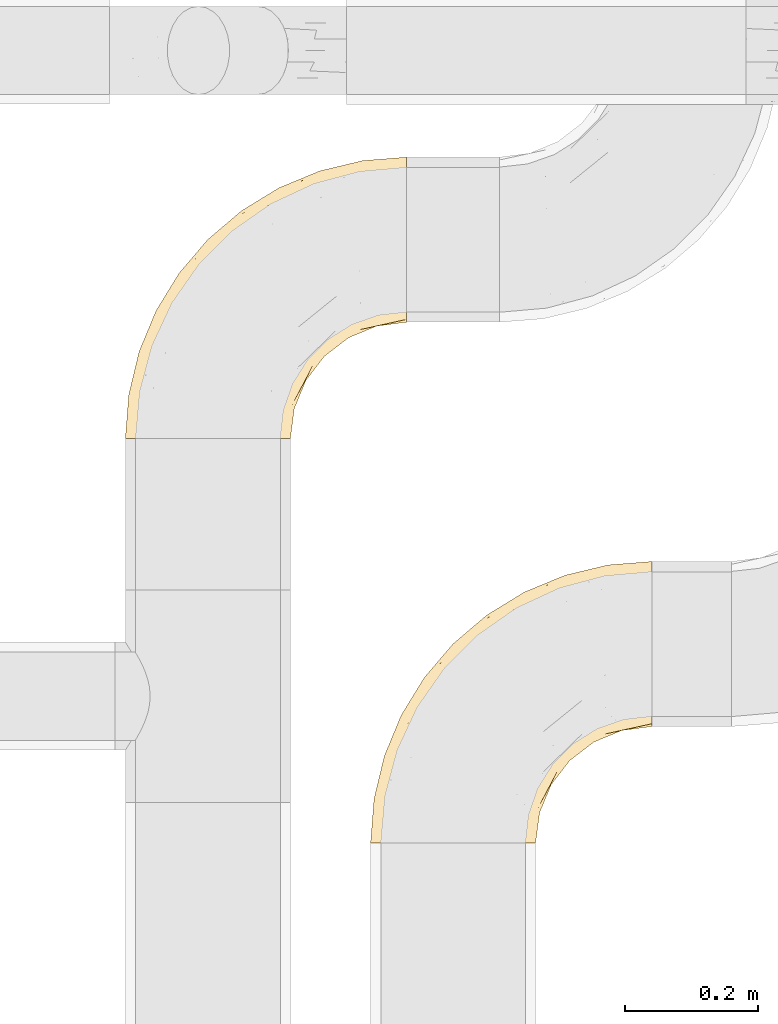
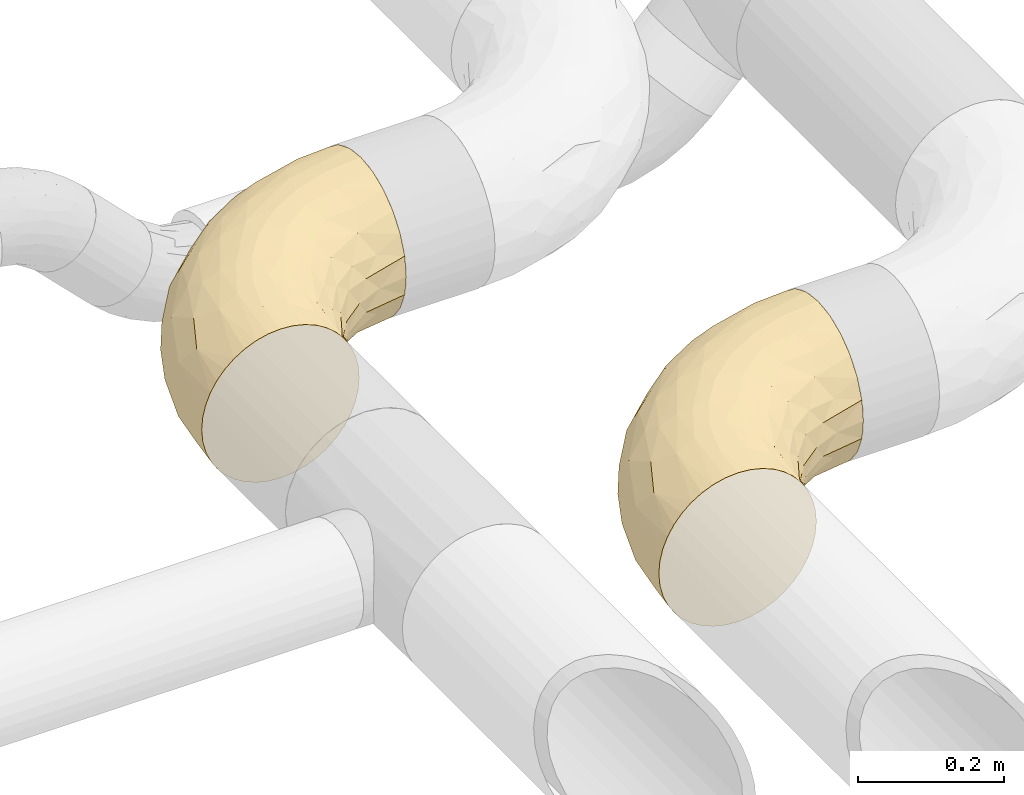
# One storey, part 38 of 93: 2 coverings.
"""IFC2X3 building model written with IfcOpenShell, lengths in millimetres."""

from ifc_helpers import new_model, entity, si_unit, converted_unit, derived_unit, direction, frame, origin, place, context, subcontext, project, spatial, faceted_brep, element, save


model = new_model("IFC2X3")

# Units and contexts
model_context = context("Model", 3, precision=0.01, world=origin(), true_north=direction((6.12303176911189e-17, 1.0)))
body_context = subcontext(model_context, "Body", "Model", "MODEL_VIEW")
ifc_project = project(units=[si_unit("LENGTHUNIT", "METRE", prefix="MILLI"), si_unit("AREAUNIT", "SQUARE_METRE"), si_unit("VOLUMEUNIT", "CUBIC_METRE"), converted_unit("PLANEANGLEUNIT", "DEGREE", entity("IfcRatioMeasure", 0.0174532925199433), si_unit("PLANEANGLEUNIT", "RADIAN"), dimensions=[0, 0, 0, 0, 0, 0, 0]), si_unit("MASSUNIT", "GRAM", prefix="KILO"), derived_unit("MASSDENSITYUNIT", [(si_unit("MASSUNIT", "GRAM", prefix="KILO"), 1), (si_unit("LENGTHUNIT", "METRE"), -3)]), derived_unit("MOMENTOFINERTIAUNIT", [(si_unit("LENGTHUNIT", "METRE"), 4)]), si_unit("TIMEUNIT", "SECOND"), si_unit("FREQUENCYUNIT", "HERTZ"), si_unit("THERMODYNAMICTEMPERATUREUNIT", "DEGREE_CELSIUS"), derived_unit("THERMALTRANSMITTANCEUNIT", [(si_unit("MASSUNIT", "GRAM", prefix="KILO"), 1), (si_unit("THERMODYNAMICTEMPERATUREUNIT", "KELVIN"), -1), (si_unit("TIMEUNIT", "SECOND"), -3)]), derived_unit("VOLUMETRICFLOWRATEUNIT", [(si_unit("LENGTHUNIT", "METRE"), 3), (si_unit("TIMEUNIT", "SECOND"), -1)]), derived_unit("MASSFLOWRATEUNIT", [(si_unit("MASSUNIT", "GRAM", prefix="KILO"), 1), (si_unit("TIMEUNIT", "SECOND"), -1)]), derived_unit("ROTATIONALFREQUENCYUNIT", [(si_unit("TIMEUNIT", "SECOND"), -1)]), si_unit("ELECTRICCURRENTUNIT", "AMPERE"), si_unit("ELECTRICVOLTAGEUNIT", "VOLT"), si_unit("POWERUNIT", "WATT"), si_unit("FORCEUNIT", "NEWTON", prefix="KILO"), si_unit("ILLUMINANCEUNIT", "LUX"), si_unit("LUMINOUSFLUXUNIT", "LUMEN"), si_unit("LUMINOUSINTENSITYUNIT", "CANDELA"), derived_unit("USERDEFINED", [(si_unit("MASSUNIT", "GRAM", prefix="KILO"), -1), (si_unit("LENGTHUNIT", "METRE"), -2), (si_unit("TIMEUNIT", "SECOND"), 3), (si_unit("LUMINOUSFLUXUNIT", "LUMEN"), 1)]), derived_unit("LINEARVELOCITYUNIT", [(si_unit("LENGTHUNIT", "METRE"), 1), (si_unit("TIMEUNIT", "SECOND"), -1)]), si_unit("PRESSUREUNIT", "PASCAL"), derived_unit("USERDEFINED", [(si_unit("LENGTHUNIT", "METRE"), -2), (si_unit("MASSUNIT", "GRAM", prefix="KILO"), 1), (si_unit("TIMEUNIT", "SECOND"), -2)]), derived_unit("LINEARFORCEUNIT", [(si_unit("MASSUNIT", "GRAM", prefix="KILO"), 1), (si_unit("LENGTHUNIT", "METRE"), 1), (si_unit("TIMEUNIT", "SECOND"), -2), (si_unit("LENGTHUNIT", "METRE"), -1)]), derived_unit("PLANARFORCEUNIT", [(si_unit("MASSUNIT", "GRAM", prefix="KILO"), 1), (si_unit("LENGTHUNIT", "METRE"), 1), (si_unit("TIMEUNIT", "SECOND"), -2), (si_unit("LENGTHUNIT", "METRE"), -2)])], contexts=[model_context])

# Site, building, storey
site_placement = place(None, origin())
site = spatial("IfcSite", under=ifc_project, at=site_placement, CompositionType="ELEMENT")
building_placement = place(site_placement, origin())
building = spatial("IfcBuilding", under=site, at=building_placement, CompositionType="ELEMENT")
storey_placement = place(building_placement, frame((0.0, 0.0, -4200.0)))
storey = spatial("IfcBuildingStorey", under=building, at=storey_placement, CompositionType="ELEMENT", Elevation=-4200.0)

# Coverings
covering_1_placement = place(storey_placement, frame((30583.69, 8277.16, 2673.9)))
element("IfcCovering", 1, at=covering_1_placement, inside=storey, Name=":ADSK_", ObjectType=":ADSK_", PredefinedType="INSULATION", context=body_context, shape_type="Brep", body=[
    faceted_brep([(145.56, 1.6, 249.06), (126.1, 1.6, 250.6), (106.62, 1.6, 249.06), (87.62, 1.6, 244.5), (69.57, 1.6, 237.02), (52.91, 1.6, 226.82), (38.06, 1.6, 214.13), (25.37, 1.6, 199.27), (15.16, 1.6, 182.61), (7.69, 1.6, 164.56), (3.13, 1.6, 145.56), (1.6, 1.6, 126.1), (3.13, 1.6, 106.62), (7.69, 1.6, 87.62), (15.17, 1.6, 69.57), (25.37, 1.6, 52.91), (38.06, 1.6, 38.06), (52.92, 1.6, 25.37), (69.58, 1.6, 15.16), (87.63, 1.6, 7.69), (106.63, 1.6, 3.13), (126.1, 1.6, 1.6), (145.57, 1.6, 3.13), (164.57, 1.6, 7.69), (182.62, 1.6, 15.17), (199.28, 1.6, 25.37), (214.13, 1.6, 38.06), (226.82, 1.6, 52.92), (237.03, 1.6, 69.58), (244.5, 1.6, 87.63), (249.06, 1.6, 106.63), (250.6, 1.6, 126.1), (249.06, 1.6, 145.57), (244.5, 1.6, 164.57), (237.02, 1.6, 182.62), (226.82, 1.6, 199.28), (214.13, 1.6, 214.13), (199.27, 1.6, 226.82), (182.61, 1.6, 237.03), (164.56, 1.6, 244.5), (426.1, 213.56, 38.06), (426.1, 239.35, 18.28), (426.1, 269.37, 5.84), (426.1, 301.6, 1.6), (426.1, 333.82, 5.84), (426.1, 363.85, 18.28), (426.1, 389.63, 38.06), (426.1, 409.42, 63.85), (426.1, 421.85, 93.87), (426.1, 426.1, 126.1), (426.1, 421.85, 158.32), (426.1, 409.42, 188.35), (426.1, 389.63, 214.13), (426.1, 363.85, 233.92), (426.1, 333.82, 246.35), (426.1, 301.6, 250.6), (426.1, 269.37, 246.35), (426.1, 239.35, 233.92), (426.1, 213.56, 214.13), (426.1, 193.78, 188.35), (426.1, 181.34, 158.32), (426.1, 177.1, 126.1), (426.1, 181.34, 93.87), (426.1, 193.78, 63.85), (359.69, 420.87, 126.1), (267.93, 390.52, 159.79), (350.05, 410.45, 171.65), (330.47, 413.12, 148.37), (21.89, 100.5, 170.98), (35.65, 161.37, 151.53), (13.18, 90.99, 148.43), (294.92, 405.32, 126.1), (233.38, 379.83, 126.1), (22.37, 132.77, 126.1), (47.86, 194.31, 126.1), (107.33, 273.0, 163.78), (179.35, 341.88, 158.07), (125.93, 301.76, 126.1), (60.98, 126.78, 216.14), (102.07, 175.34, 230.6), (92.62, 197.92, 215.18), (333.29, 344.83, 237.51), (292.95, 359.37, 220.0), (248.51, 301.84, 240.62), (176.58, 345.02, 126.1), (215.93, 352.47, 186.25), (82.67, 251.11, 126.1), (85.57, 97.73, 238.35), (368.18, 375.5, 222.84), (216.04, 252.9, 247.51), (130.19, 174.94, 242.96), (151.09, 168.15, 248.72), (317.03, 310.43, 247.51), (332.35, 391.69, 198.61), (173.74, 249.69, 238.33), (311.29, 278.76, 250.6), (259.42, 251.04, 250.6), (58.28, 182.02, 185.0), (213.96, 213.73, 250.6), (121.69, 265.35, 196.36), (36.14, 75.24, 204.33), (6.82, 68.0, 126.1), (131.86, 60.12, 250.6), (119.41, 108.56, 248.1), (176.65, 168.27, 250.6), (148.93, 116.4, 250.6), (367.57, 295.83, 250.6), (192.91, 315.85, 210.72), (206.0, 300.02, 228.5), (263.73, 365.06, 202.78), (138.74, 247.44, 223.0), (315.71, 144.62, 161.59), (338.35, 153.58, 126.1), (355.82, 165.92, 154.22), (362.95, 258.71, 245.5), (211.87, 87.33, 229.55), (205.55, 47.08, 225.61), (226.18, 74.58, 214.98), (301.17, 166.65, 208.87), (255.32, 142.22, 222.51), (263.89, 121.62, 202.61), (192.91, 92.94, 240.31), (260.02, 91.52, 182.2), (253.73, 53.04, 158.82), (284.35, 111.31, 156.41), (305.74, 245.91, 247.49), (168.84, 55.96, 244.95), (284.44, 183.54, 229.45), (258.04, 211.66, 246.68), (376.69, 227.63, 229.97), (380.67, 171.12, 126.1), (381.95, 181.99, 175.48), (334.49, 166.86, 182.39), (256.58, 47.02, 126.1), (274.11, 89.35, 126.1), (291.38, 135.0, 183.62), (302.0, 125.69, 126.1), (222.21, 163.44, 244.1), (178.36, 125.41, 248.44), (361.45, 198.38, 209.02), (223.16, 129.94, 235.25), (249.92, 165.64, 235.58), (242.28, 48.55, 183.86), (320.19, 217.22, 235.31), (258.03, 211.66, 5.51), (284.47, 183.55, 22.75), (249.93, 165.65, 16.61), (315.71, 144.62, 90.61), (334.49, 166.86, 69.8), (355.82, 165.92, 97.97), (205.56, 47.08, 26.59), (311.29, 278.76, 1.6), (305.74, 245.91, 4.7), (259.42, 251.04, 1.6), (284.35, 111.31, 95.79), (211.88, 87.33, 22.64), (192.92, 92.95, 11.89), (291.39, 134.99, 68.58), (253.73, 53.04, 93.38), (362.95, 258.71, 6.69), (367.57, 295.83, 1.6), (213.96, 213.73, 1.6), (222.21, 163.45, 8.09), (223.16, 129.95, 16.94), (301.16, 166.63, 43.34), (376.69, 227.63, 22.22), (361.45, 198.38, 43.17), (260.03, 91.52, 70.0), (148.93, 116.4, 1.6), (168.85, 55.97, 7.24), (131.86, 60.12, 1.6), (381.95, 181.99, 76.71), (242.29, 48.55, 68.34), (320.19, 217.22, 16.88), (226.19, 74.58, 37.22), (255.33, 142.23, 29.69), (263.89, 121.62, 49.59), (178.36, 125.4, 3.75), (176.65, 168.27, 1.6), (317.03, 310.43, 4.68), (138.74, 247.44, 29.2), (102.06, 175.33, 21.6), (92.61, 197.92, 37.02), (216.04, 252.9, 4.68), (58.28, 182.0, 67.18), (21.89, 100.49, 81.2), (35.65, 161.37, 100.65), (85.57, 97.72, 13.83), (333.29, 344.83, 14.68), (368.18, 375.5, 29.35), (332.35, 391.69, 53.58), (130.19, 174.94, 9.24), (151.09, 168.15, 3.47), (248.51, 301.84, 11.57), (267.93, 390.52, 92.4), (350.05, 410.45, 80.54), (36.14, 75.24, 47.86), (292.95, 359.37, 32.19), (107.33, 273.0, 88.4), (121.68, 265.34, 55.83), (330.47, 413.12, 103.83), (179.36, 341.88, 94.12), (215.93, 352.47, 65.94), (192.9, 315.85, 41.48), (13.18, 90.98, 103.76), (119.41, 108.56, 4.09), (173.74, 249.69, 13.86), (206.0, 300.02, 23.69), (60.99, 126.78, 36.04), (263.73, 365.06, 49.41)], [[[0, 1, 2, 3, 4, 5, 6, 7, 8, 9, 10, 11, 12, 13, 14, 15, 16, 17, 18, 19, 20, 21, 22, 23, 24, 25, 26, 27, 28, 29, 30, 31, 32, 33, 34, 35, 36, 37, 38, 39]], [[40, 41, 42, 43, 44, 45, 46, 47, 48, 49, 50, 51, 52, 53, 54, 55, 56, 57, 58, 59, 60, 61, 62, 63]], [[49, 64, 50]], [[65, 66, 67]], [[68, 69, 70]], [[65, 71, 72]], [[71, 65, 67]], [[73, 69, 74]], [[75, 76, 77]], [[78, 79, 80]], [[65, 72, 76]], [[51, 50, 66]], [[81, 82, 83]], [[84, 76, 72]], [[76, 85, 65]], [[74, 69, 86]], [[5, 87, 78]], [[52, 88, 53]], [[89, 90, 91]], [[55, 54, 92]], [[82, 88, 93]], [[94, 89, 83]], [[87, 90, 79]], [[95, 89, 96]], [[5, 4, 87]], [[83, 89, 92]], [[90, 89, 94]], [[78, 80, 97]], [[65, 85, 93]], [[95, 92, 89]], [[96, 89, 98]], [[99, 75, 97]], [[3, 87, 4]], [[90, 94, 79]], [[8, 68, 9]], [[75, 77, 86]], [[100, 7, 6]], [[83, 92, 81]], [[70, 10, 9]], [[101, 70, 73]], [[54, 81, 92]], [[68, 70, 9]], [[97, 100, 78]], [[7, 100, 8]], [[8, 100, 68]], [[101, 11, 10]], [[2, 102, 103]], [[100, 6, 5]], [[104, 91, 105]], [[102, 105, 103]], [[92, 95, 106]], [[1, 102, 2]], [[81, 54, 53]], [[107, 108, 82]], [[68, 97, 69]], [[2, 103, 3]], [[98, 89, 91]], [[90, 103, 91]], [[90, 87, 103]], [[107, 85, 99]], [[103, 87, 3]], [[100, 97, 68]], [[100, 5, 78]], [[93, 52, 51]], [[75, 69, 97]], [[75, 86, 69]], [[88, 81, 53]], [[55, 92, 106]], [[93, 51, 66]], [[109, 82, 93]], [[108, 94, 83]], [[79, 94, 110]], [[107, 99, 110]], [[85, 75, 99]], [[77, 76, 84]], [[75, 85, 76]], [[110, 94, 108]], [[109, 107, 82]], [[82, 108, 83]], [[110, 108, 107]], [[67, 50, 64]], [[93, 66, 65]], [[80, 79, 110]], [[78, 87, 79]], [[110, 99, 80]], [[97, 80, 99]], [[73, 70, 69]], [[10, 70, 101]], [[50, 67, 66]], [[71, 67, 64]], [[105, 91, 103]], [[91, 104, 98]], [[93, 88, 52]], [[81, 88, 82]], [[93, 85, 109]], [[107, 109, 85]], [[111, 112, 113]], [[56, 55, 106]], [[106, 114, 56]], [[115, 116, 117]], [[118, 119, 120]], [[116, 115, 121]], [[95, 114, 106]], [[122, 123, 124]], [[95, 125, 114]], [[102, 39, 126]], [[119, 118, 127]], [[96, 98, 128]], [[114, 57, 56]], [[57, 129, 58]], [[36, 35, 116]], [[61, 60, 130]], [[113, 131, 132]], [[32, 133, 123]], [[134, 123, 133]], [[113, 112, 130]], [[126, 116, 121]], [[131, 113, 60]], [[124, 111, 135]], [[122, 124, 135]], [[111, 136, 112]], [[128, 98, 137]], [[137, 104, 138]], [[132, 135, 111]], [[126, 105, 102]], [[60, 113, 130]], [[127, 118, 139]], [[126, 39, 38]], [[140, 121, 115]], [[1, 0, 102]], [[126, 121, 138]], [[38, 37, 116]], [[129, 139, 58]], [[0, 39, 102]], [[127, 141, 119]], [[116, 126, 38]], [[142, 34, 33]], [[142, 123, 122]], [[137, 98, 104]], [[31, 133, 32]], [[139, 132, 131]], [[123, 134, 124]], [[35, 34, 142]], [[35, 117, 116]], [[124, 134, 136]], [[117, 122, 120]], [[33, 32, 123]], [[33, 123, 142]], [[37, 36, 116]], [[58, 139, 59]], [[129, 114, 143]], [[105, 138, 104]], [[125, 128, 143]], [[125, 95, 96]], [[118, 135, 132]], [[120, 122, 135]], [[132, 139, 118]], [[127, 139, 143]], [[114, 129, 57]], [[139, 129, 143]], [[60, 59, 131]], [[139, 131, 59]], [[128, 125, 96]], [[143, 114, 125]], [[118, 120, 135]], [[117, 120, 119]], [[143, 128, 127]], [[141, 128, 137]], [[136, 111, 124]], [[132, 111, 113]], [[122, 117, 142]], [[35, 142, 117]], [[117, 119, 115]], [[119, 141, 140]], [[126, 138, 105]], [[137, 138, 121]], [[128, 141, 127]], [[140, 141, 137]], [[121, 140, 137]], [[119, 140, 115]], [[144, 145, 146]], [[147, 148, 149]], [[62, 61, 130]], [[149, 62, 130]], [[26, 150, 27]], [[151, 152, 153]], [[134, 154, 136]], [[155, 150, 156]], [[130, 112, 149]], [[157, 147, 154]], [[152, 144, 153]], [[154, 134, 158]], [[42, 159, 160]], [[161, 153, 144]], [[162, 146, 163]], [[160, 43, 42]], [[41, 159, 42]], [[164, 148, 157]], [[41, 40, 165]], [[40, 63, 166]], [[158, 167, 154]], [[151, 160, 159]], [[168, 169, 170]], [[63, 171, 166]], [[23, 170, 169]], [[152, 151, 159]], [[29, 172, 158]], [[173, 166, 145]], [[133, 31, 30]], [[149, 148, 171]], [[144, 162, 161]], [[172, 29, 28]], [[174, 172, 27]], [[149, 171, 62]], [[174, 27, 150]], [[158, 134, 133]], [[155, 174, 150]], [[167, 158, 172]], [[174, 175, 176]], [[162, 156, 177]], [[169, 168, 177]], [[162, 178, 161]], [[26, 25, 150]], [[166, 164, 145]], [[23, 169, 24]], [[169, 150, 24]], [[169, 156, 150]], [[136, 154, 147]], [[22, 21, 170]], [[133, 30, 158]], [[150, 25, 24]], [[23, 22, 170]], [[157, 154, 167]], [[178, 177, 168]], [[112, 136, 147]], [[29, 158, 30]], [[165, 159, 41]], [[165, 166, 173]], [[167, 176, 157]], [[157, 176, 164]], [[164, 175, 145]], [[166, 148, 164]], [[166, 165, 40]], [[159, 165, 173]], [[166, 171, 148]], [[63, 62, 171]], [[159, 173, 152]], [[144, 152, 173]], [[174, 176, 167]], [[164, 176, 175]], [[146, 145, 175]], [[144, 173, 145]], [[148, 147, 157]], [[147, 149, 112]], [[27, 172, 28]], [[174, 167, 172]], [[163, 156, 162]], [[175, 174, 155]], [[162, 177, 178]], [[169, 177, 156]], [[163, 175, 155]], [[144, 146, 162]], [[175, 163, 146]], [[156, 163, 155]], [[160, 179, 43]], [[180, 181, 182]], [[151, 153, 183]], [[184, 185, 186]], [[183, 179, 151]], [[186, 74, 86]], [[153, 161, 183]], [[187, 19, 18]], [[188, 44, 179]], [[46, 189, 190]], [[181, 191, 187]], [[183, 161, 192]], [[186, 73, 74]], [[193, 179, 183]], [[194, 195, 190]], [[184, 196, 185]], [[64, 49, 48]], [[44, 188, 45]], [[193, 188, 179]], [[189, 188, 197]], [[14, 13, 185]], [[198, 199, 184]], [[195, 200, 48]], [[201, 194, 202]], [[182, 184, 199]], [[201, 77, 84]], [[199, 203, 180]], [[194, 201, 72]], [[45, 189, 46]], [[13, 12, 204]], [[205, 192, 168]], [[14, 196, 15]], [[170, 21, 20]], [[186, 86, 198]], [[187, 205, 19]], [[19, 205, 20]], [[20, 205, 170]], [[151, 179, 160]], [[205, 191, 192]], [[193, 206, 207]], [[208, 17, 196]], [[193, 197, 188]], [[43, 179, 44]], [[187, 17, 208]], [[46, 190, 47]], [[84, 72, 201]], [[198, 184, 186]], [[86, 77, 198]], [[194, 72, 71]], [[186, 204, 73]], [[204, 186, 185]], [[15, 196, 16]], [[184, 208, 196]], [[192, 161, 178]], [[12, 11, 101]], [[17, 187, 18]], [[47, 195, 48]], [[12, 101, 204]], [[181, 180, 206]], [[17, 16, 196]], [[14, 185, 196]], [[168, 170, 205]], [[206, 183, 191]], [[183, 206, 193]], [[187, 191, 205]], [[200, 71, 64]], [[197, 209, 190]], [[194, 190, 202]], [[181, 206, 191]], [[207, 180, 203]], [[198, 202, 199]], [[203, 199, 202]], [[202, 198, 201]], [[77, 201, 198]], [[209, 203, 202]], [[207, 197, 193]], [[180, 207, 206]], [[197, 207, 203]], [[190, 195, 47]], [[200, 195, 194]], [[187, 208, 181]], [[182, 181, 208]], [[184, 182, 208]], [[199, 180, 182]], [[204, 185, 13]], [[73, 204, 101]], [[71, 200, 194]], [[48, 200, 64]], [[183, 192, 191]], [[168, 192, 178]], [[188, 189, 45]], [[190, 189, 197]], [[203, 209, 197]], [[202, 190, 209]]]),
])
covering_2_placement = place(storey_placement, frame((30213.69, 8887.16, 2673.9)))
element("IfcCovering", 2, at=covering_2_placement, inside=storey, Name=":ADSK_", ObjectType=":ADSK_", PredefinedType="INSULATION", context=body_context, shape_type="Brep", body=[
    faceted_brep([(145.56, 1.6, 249.06), (126.1, 1.6, 250.6), (106.62, 1.6, 249.06), (87.62, 1.6, 244.5), (69.57, 1.6, 237.02), (52.91, 1.6, 226.82), (38.06, 1.6, 214.13), (25.37, 1.6, 199.27), (15.16, 1.6, 182.61), (7.69, 1.6, 164.56), (3.13, 1.6, 145.56), (1.6, 1.6, 126.1), (3.13, 1.6, 106.62), (7.69, 1.6, 87.62), (15.17, 1.6, 69.57), (25.37, 1.6, 52.91), (38.06, 1.6, 38.06), (52.92, 1.6, 25.37), (69.58, 1.6, 15.16), (87.63, 1.6, 7.69), (106.63, 1.6, 3.13), (126.1, 1.6, 1.6), (145.57, 1.6, 3.13), (164.57, 1.6, 7.69), (182.62, 1.6, 15.17), (199.28, 1.6, 25.37), (214.13, 1.6, 38.06), (226.82, 1.6, 52.92), (237.03, 1.6, 69.58), (244.5, 1.6, 87.63), (249.06, 1.6, 106.63), (250.6, 1.6, 126.1), (249.06, 1.6, 145.57), (244.5, 1.6, 164.57), (237.02, 1.6, 182.62), (226.82, 1.6, 199.28), (214.13, 1.6, 214.13), (199.27, 1.6, 226.82), (182.61, 1.6, 237.03), (164.56, 1.6, 244.5), (426.1, 213.56, 38.06), (426.1, 239.35, 18.28), (426.1, 269.37, 5.84), (426.1, 301.6, 1.6), (426.1, 333.82, 5.84), (426.1, 363.85, 18.28), (426.1, 389.63, 38.06), (426.1, 409.42, 63.85), (426.1, 421.85, 93.87), (426.1, 426.1, 126.1), (426.1, 421.85, 158.32), (426.1, 409.42, 188.35), (426.1, 389.63, 214.13), (426.1, 363.85, 233.92), (426.1, 333.82, 246.35), (426.1, 301.6, 250.6), (426.1, 269.37, 246.35), (426.1, 239.35, 233.92), (426.1, 213.56, 214.13), (426.1, 193.78, 188.35), (426.1, 181.34, 158.32), (426.1, 177.1, 126.1), (426.1, 181.34, 93.87), (426.1, 193.78, 63.85), (359.69, 420.87, 126.1), (267.93, 390.52, 159.79), (350.05, 410.45, 171.65), (330.47, 413.12, 148.37), (21.89, 100.5, 170.98), (35.65, 161.37, 151.53), (13.18, 90.99, 148.43), (294.92, 405.32, 126.1), (233.38, 379.83, 126.1), (22.37, 132.77, 126.1), (47.86, 194.31, 126.1), (107.33, 273.0, 163.78), (179.35, 341.88, 158.07), (125.93, 301.76, 126.1), (60.98, 126.78, 216.14), (102.07, 175.34, 230.6), (92.62, 197.92, 215.18), (333.29, 344.83, 237.51), (292.95, 359.37, 220.0), (248.51, 301.84, 240.62), (176.58, 345.02, 126.1), (215.93, 352.47, 186.25), (82.67, 251.11, 126.1), (85.57, 97.73, 238.35), (368.18, 375.5, 222.84), (216.04, 252.9, 247.51), (130.19, 174.94, 242.96), (151.09, 168.15, 248.72), (317.03, 310.43, 247.51), (332.35, 391.69, 198.61), (173.74, 249.69, 238.33), (311.29, 278.76, 250.6), (259.42, 251.04, 250.6), (58.28, 182.02, 185.0), (213.96, 213.73, 250.6), (121.69, 265.35, 196.36), (36.14, 75.24, 204.33), (6.82, 68.0, 126.1), (131.86, 60.12, 250.6), (119.41, 108.56, 248.1), (176.65, 168.27, 250.6), (148.93, 116.4, 250.6), (367.57, 295.83, 250.6), (192.91, 315.85, 210.72), (206.0, 300.02, 228.5), (263.73, 365.06, 202.78), (138.74, 247.44, 223.0), (315.71, 144.62, 161.59), (338.35, 153.58, 126.1), (355.82, 165.92, 154.22), (362.95, 258.71, 245.5), (211.87, 87.33, 229.55), (205.55, 47.08, 225.61), (226.18, 74.58, 214.98), (301.17, 166.65, 208.87), (255.32, 142.22, 222.51), (263.89, 121.62, 202.61), (192.91, 92.94, 240.31), (260.02, 91.52, 182.2), (253.73, 53.04, 158.82), (284.35, 111.31, 156.41), (305.74, 245.91, 247.49), (168.84, 55.96, 244.95), (284.44, 183.54, 229.45), (258.04, 211.66, 246.68), (376.69, 227.63, 229.97), (380.67, 171.12, 126.1), (381.95, 181.99, 175.48), (334.49, 166.86, 182.39), (256.58, 47.02, 126.1), (274.11, 89.35, 126.1), (291.38, 135.0, 183.62), (302.0, 125.69, 126.1), (222.21, 163.44, 244.1), (178.36, 125.41, 248.44), (361.45, 198.38, 209.02), (223.16, 129.94, 235.25), (249.92, 165.64, 235.58), (242.28, 48.55, 183.86), (320.19, 217.22, 235.31), (258.03, 211.66, 5.51), (284.47, 183.55, 22.75), (249.93, 165.65, 16.61), (315.71, 144.62, 90.61), (334.49, 166.86, 69.8), (355.82, 165.92, 97.97), (205.56, 47.08, 26.59), (311.29, 278.76, 1.6), (305.74, 245.91, 4.7), (259.42, 251.04, 1.6), (284.35, 111.31, 95.79), (211.88, 87.33, 22.64), (192.92, 92.95, 11.89), (291.39, 134.99, 68.58), (253.73, 53.04, 93.38), (362.95, 258.71, 6.69), (367.57, 295.83, 1.6), (213.96, 213.73, 1.6), (222.21, 163.45, 8.09), (223.16, 129.95, 16.94), (301.16, 166.63, 43.34), (376.69, 227.63, 22.22), (361.45, 198.38, 43.17), (260.03, 91.52, 70.0), (148.93, 116.4, 1.6), (168.85, 55.97, 7.24), (131.86, 60.12, 1.6), (381.95, 181.99, 76.71), (242.29, 48.55, 68.34), (320.19, 217.22, 16.88), (226.19, 74.58, 37.22), (255.33, 142.23, 29.69), (263.89, 121.62, 49.59), (178.36, 125.4, 3.75), (176.65, 168.27, 1.6), (317.03, 310.43, 4.68), (138.74, 247.44, 29.2), (102.06, 175.33, 21.6), (92.61, 197.92, 37.02), (216.04, 252.9, 4.68), (58.28, 182.0, 67.18), (21.89, 100.49, 81.2), (35.65, 161.37, 100.65), (85.57, 97.72, 13.83), (333.29, 344.83, 14.68), (368.18, 375.5, 29.35), (332.35, 391.69, 53.58), (130.19, 174.94, 9.24), (151.09, 168.15, 3.47), (248.51, 301.84, 11.57), (267.93, 390.52, 92.4), (350.05, 410.45, 80.54), (36.14, 75.24, 47.86), (292.95, 359.37, 32.19), (107.33, 273.0, 88.4), (121.68, 265.34, 55.83), (330.47, 413.12, 103.83), (179.36, 341.88, 94.12), (215.93, 352.47, 65.94), (192.9, 315.85, 41.48), (13.18, 90.98, 103.76), (119.41, 108.56, 4.09), (173.74, 249.69, 13.86), (206.0, 300.02, 23.69), (60.99, 126.78, 36.04), (263.73, 365.06, 49.41)], [[[0, 1, 2, 3, 4, 5, 6, 7, 8, 9, 10, 11, 12, 13, 14, 15, 16, 17, 18, 19, 20, 21, 22, 23, 24, 25, 26, 27, 28, 29, 30, 31, 32, 33, 34, 35, 36, 37, 38, 39]], [[40, 41, 42, 43, 44, 45, 46, 47, 48, 49, 50, 51, 52, 53, 54, 55, 56, 57, 58, 59, 60, 61, 62, 63]], [[49, 64, 50]], [[65, 66, 67]], [[68, 69, 70]], [[65, 71, 72]], [[71, 65, 67]], [[73, 69, 74]], [[75, 76, 77]], [[78, 79, 80]], [[65, 72, 76]], [[51, 50, 66]], [[81, 82, 83]], [[84, 76, 72]], [[76, 85, 65]], [[74, 69, 86]], [[5, 87, 78]], [[52, 88, 53]], [[89, 90, 91]], [[55, 54, 92]], [[82, 88, 93]], [[94, 89, 83]], [[87, 90, 79]], [[95, 89, 96]], [[5, 4, 87]], [[83, 89, 92]], [[90, 89, 94]], [[78, 80, 97]], [[65, 85, 93]], [[95, 92, 89]], [[96, 89, 98]], [[99, 75, 97]], [[3, 87, 4]], [[90, 94, 79]], [[8, 68, 9]], [[75, 77, 86]], [[100, 7, 6]], [[83, 92, 81]], [[70, 10, 9]], [[101, 70, 73]], [[54, 81, 92]], [[68, 70, 9]], [[97, 100, 78]], [[7, 100, 8]], [[8, 100, 68]], [[101, 11, 10]], [[2, 102, 103]], [[100, 6, 5]], [[104, 91, 105]], [[102, 105, 103]], [[92, 95, 106]], [[1, 102, 2]], [[81, 54, 53]], [[107, 108, 82]], [[68, 97, 69]], [[2, 103, 3]], [[98, 89, 91]], [[90, 103, 91]], [[90, 87, 103]], [[107, 85, 99]], [[103, 87, 3]], [[100, 97, 68]], [[100, 5, 78]], [[93, 52, 51]], [[75, 69, 97]], [[75, 86, 69]], [[88, 81, 53]], [[55, 92, 106]], [[93, 51, 66]], [[109, 82, 93]], [[108, 94, 83]], [[79, 94, 110]], [[107, 99, 110]], [[85, 75, 99]], [[77, 76, 84]], [[75, 85, 76]], [[110, 94, 108]], [[109, 107, 82]], [[82, 108, 83]], [[110, 108, 107]], [[67, 50, 64]], [[93, 66, 65]], [[80, 79, 110]], [[78, 87, 79]], [[110, 99, 80]], [[97, 80, 99]], [[73, 70, 69]], [[10, 70, 101]], [[50, 67, 66]], [[71, 67, 64]], [[105, 91, 103]], [[91, 104, 98]], [[93, 88, 52]], [[81, 88, 82]], [[93, 85, 109]], [[107, 109, 85]], [[111, 112, 113]], [[56, 55, 106]], [[106, 114, 56]], [[115, 116, 117]], [[118, 119, 120]], [[116, 115, 121]], [[95, 114, 106]], [[122, 123, 124]], [[95, 125, 114]], [[102, 39, 126]], [[119, 118, 127]], [[96, 98, 128]], [[114, 57, 56]], [[57, 129, 58]], [[36, 35, 116]], [[61, 60, 130]], [[113, 131, 132]], [[32, 133, 123]], [[134, 123, 133]], [[113, 112, 130]], [[126, 116, 121]], [[131, 113, 60]], [[124, 111, 135]], [[122, 124, 135]], [[111, 136, 112]], [[128, 98, 137]], [[137, 104, 138]], [[132, 135, 111]], [[126, 105, 102]], [[60, 113, 130]], [[127, 118, 139]], [[126, 39, 38]], [[140, 121, 115]], [[1, 0, 102]], [[126, 121, 138]], [[38, 37, 116]], [[129, 139, 58]], [[0, 39, 102]], [[127, 141, 119]], [[116, 126, 38]], [[142, 34, 33]], [[142, 123, 122]], [[137, 98, 104]], [[31, 133, 32]], [[139, 132, 131]], [[123, 134, 124]], [[35, 34, 142]], [[35, 117, 116]], [[124, 134, 136]], [[117, 122, 120]], [[33, 32, 123]], [[33, 123, 142]], [[37, 36, 116]], [[58, 139, 59]], [[129, 114, 143]], [[105, 138, 104]], [[125, 128, 143]], [[125, 95, 96]], [[118, 135, 132]], [[120, 122, 135]], [[132, 139, 118]], [[127, 139, 143]], [[114, 129, 57]], [[139, 129, 143]], [[60, 59, 131]], [[139, 131, 59]], [[128, 125, 96]], [[143, 114, 125]], [[118, 120, 135]], [[117, 120, 119]], [[143, 128, 127]], [[141, 128, 137]], [[136, 111, 124]], [[132, 111, 113]], [[122, 117, 142]], [[35, 142, 117]], [[117, 119, 115]], [[119, 141, 140]], [[126, 138, 105]], [[137, 138, 121]], [[128, 141, 127]], [[140, 141, 137]], [[121, 140, 137]], [[119, 140, 115]], [[144, 145, 146]], [[147, 148, 149]], [[62, 61, 130]], [[149, 62, 130]], [[26, 150, 27]], [[151, 152, 153]], [[134, 154, 136]], [[155, 150, 156]], [[130, 112, 149]], [[157, 147, 154]], [[152, 144, 153]], [[154, 134, 158]], [[42, 159, 160]], [[161, 153, 144]], [[162, 146, 163]], [[160, 43, 42]], [[41, 159, 42]], [[164, 148, 157]], [[41, 40, 165]], [[40, 63, 166]], [[158, 167, 154]], [[151, 160, 159]], [[168, 169, 170]], [[63, 171, 166]], [[23, 170, 169]], [[152, 151, 159]], [[29, 172, 158]], [[173, 166, 145]], [[133, 31, 30]], [[149, 148, 171]], [[144, 162, 161]], [[172, 29, 28]], [[174, 172, 27]], [[149, 171, 62]], [[174, 27, 150]], [[158, 134, 133]], [[155, 174, 150]], [[167, 158, 172]], [[174, 175, 176]], [[162, 156, 177]], [[169, 168, 177]], [[162, 178, 161]], [[26, 25, 150]], [[166, 164, 145]], [[23, 169, 24]], [[169, 150, 24]], [[169, 156, 150]], [[136, 154, 147]], [[22, 21, 170]], [[133, 30, 158]], [[150, 25, 24]], [[23, 22, 170]], [[157, 154, 167]], [[178, 177, 168]], [[112, 136, 147]], [[29, 158, 30]], [[165, 159, 41]], [[165, 166, 173]], [[167, 176, 157]], [[157, 176, 164]], [[164, 175, 145]], [[166, 148, 164]], [[166, 165, 40]], [[159, 165, 173]], [[166, 171, 148]], [[63, 62, 171]], [[159, 173, 152]], [[144, 152, 173]], [[174, 176, 167]], [[164, 176, 175]], [[146, 145, 175]], [[144, 173, 145]], [[148, 147, 157]], [[147, 149, 112]], [[27, 172, 28]], [[174, 167, 172]], [[163, 156, 162]], [[175, 174, 155]], [[162, 177, 178]], [[169, 177, 156]], [[163, 175, 155]], [[144, 146, 162]], [[175, 163, 146]], [[156, 163, 155]], [[160, 179, 43]], [[180, 181, 182]], [[151, 153, 183]], [[184, 185, 186]], [[183, 179, 151]], [[186, 74, 86]], [[153, 161, 183]], [[187, 19, 18]], [[188, 44, 179]], [[46, 189, 190]], [[181, 191, 187]], [[183, 161, 192]], [[186, 73, 74]], [[193, 179, 183]], [[194, 195, 190]], [[184, 196, 185]], [[64, 49, 48]], [[44, 188, 45]], [[193, 188, 179]], [[189, 188, 197]], [[14, 13, 185]], [[198, 199, 184]], [[195, 200, 48]], [[201, 194, 202]], [[182, 184, 199]], [[201, 77, 84]], [[199, 203, 180]], [[194, 201, 72]], [[45, 189, 46]], [[13, 12, 204]], [[205, 192, 168]], [[14, 196, 15]], [[170, 21, 20]], [[186, 86, 198]], [[187, 205, 19]], [[19, 205, 20]], [[20, 205, 170]], [[151, 179, 160]], [[205, 191, 192]], [[193, 206, 207]], [[208, 17, 196]], [[193, 197, 188]], [[43, 179, 44]], [[187, 17, 208]], [[46, 190, 47]], [[84, 72, 201]], [[198, 184, 186]], [[86, 77, 198]], [[194, 72, 71]], [[186, 204, 73]], [[204, 186, 185]], [[15, 196, 16]], [[184, 208, 196]], [[192, 161, 178]], [[12, 11, 101]], [[17, 187, 18]], [[47, 195, 48]], [[12, 101, 204]], [[181, 180, 206]], [[17, 16, 196]], [[14, 185, 196]], [[168, 170, 205]], [[206, 183, 191]], [[183, 206, 193]], [[187, 191, 205]], [[200, 71, 64]], [[197, 209, 190]], [[194, 190, 202]], [[181, 206, 191]], [[207, 180, 203]], [[198, 202, 199]], [[203, 199, 202]], [[202, 198, 201]], [[77, 201, 198]], [[209, 203, 202]], [[207, 197, 193]], [[180, 207, 206]], [[197, 207, 203]], [[190, 195, 47]], [[200, 195, 194]], [[187, 208, 181]], [[182, 181, 208]], [[184, 182, 208]], [[199, 180, 182]], [[204, 185, 13]], [[73, 204, 101]], [[71, 200, 194]], [[48, 200, 64]], [[183, 192, 191]], [[168, 192, 178]], [[188, 189, 45]], [[190, 189, 197]], [[203, 209, 197]], [[202, 190, 209]]]),
])

save(model, "model.ifc")
